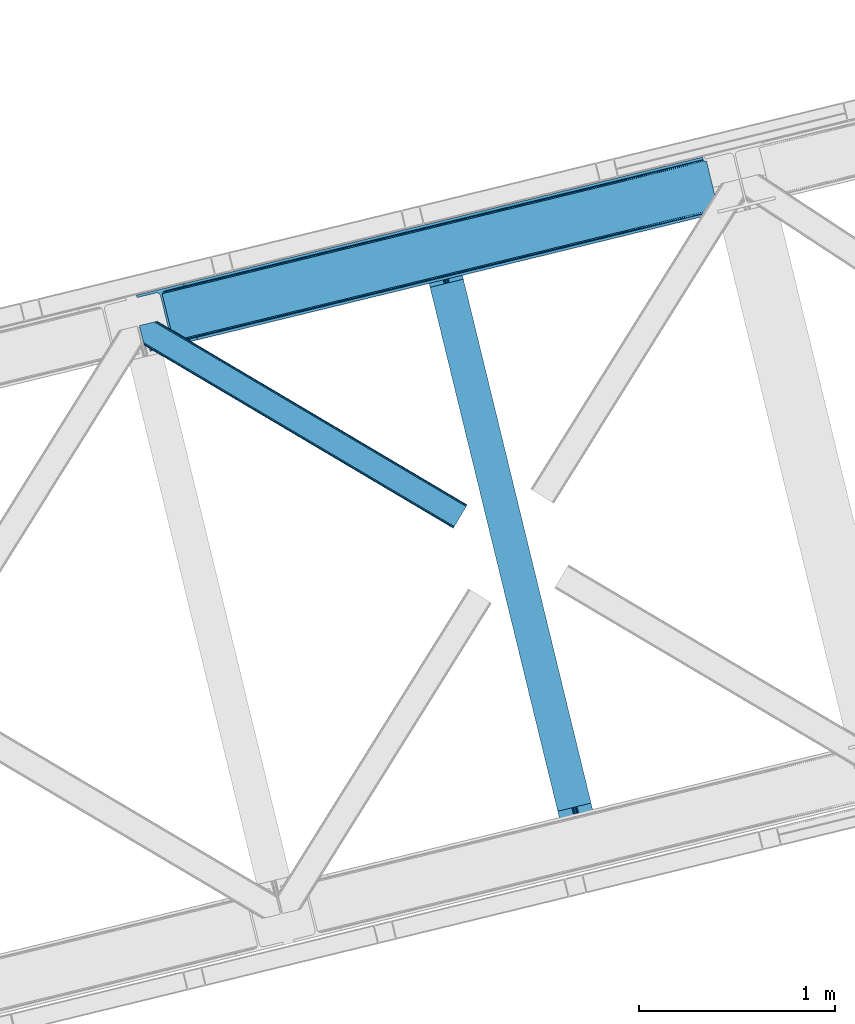
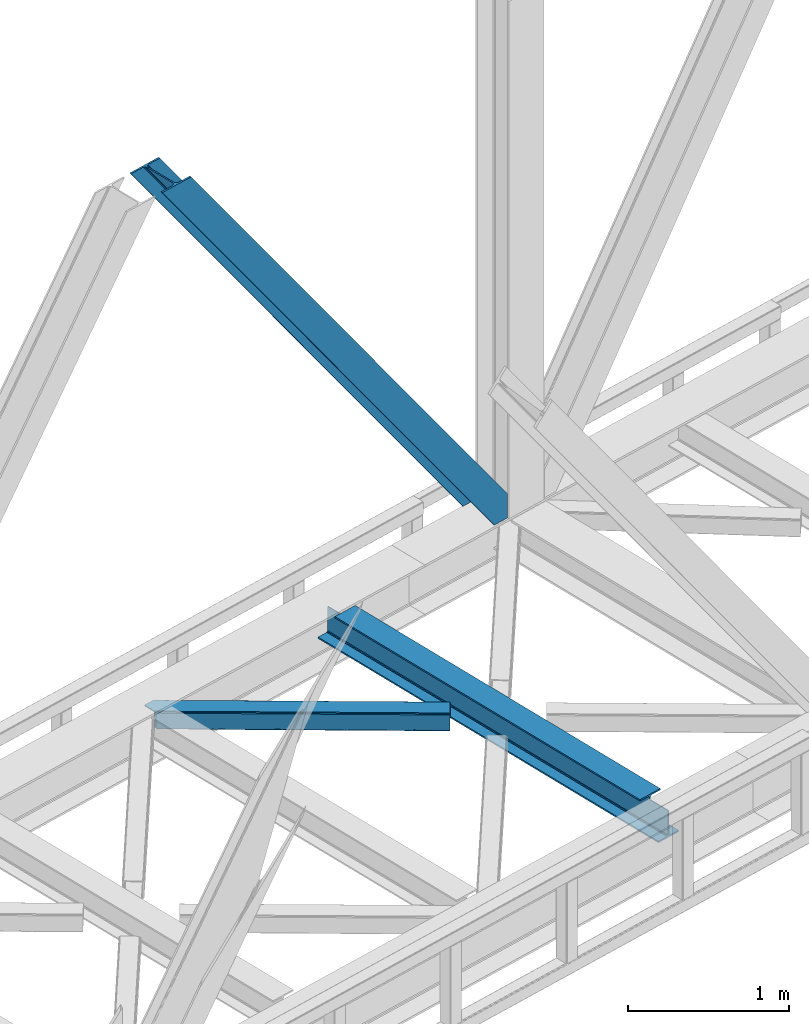
# One storey, part 76 of 92: 2 members, 1 beam.
"""IFC4 building model written with IfcOpenShell, lengths in millimetres."""

from ifc_helpers import new_model, entity, si_unit, converted_unit, derived_unit, direction, frame, origin, place, context, subcontext, project, spatial, triangles, polygons, material, type_object, element, save


model = new_model("IFC4")

# Units and contexts
model_context = context("Model", 3, precision=0.01, world=origin(), true_north=direction((6.12303176911189e-17, 1.0)))
plan_context = context("Plan", 3, precision=0.01, world=origin(), true_north=direction((6.12303176911189e-17, 1.0)))
body_context = subcontext(model_context, "Body", "Model", "MODEL_VIEW")
ifc_project = project(units=[si_unit("LENGTHUNIT", "METRE", prefix="MILLI"), si_unit("AREAUNIT", "SQUARE_METRE"), si_unit("VOLUMEUNIT", "CUBIC_METRE"), converted_unit("PLANEANGLEUNIT", "DEGREE", entity("IfcRatioMeasure", 0.0174532925199433), si_unit("PLANEANGLEUNIT", "RADIAN"), dimensions=[0, 0, 0, 0, 0, 0, 0]), si_unit("MASSUNIT", "GRAM", prefix="KILO"), derived_unit("MASSDENSITYUNIT", [(si_unit("MASSUNIT", "GRAM", prefix="KILO"), 1), (si_unit("LENGTHUNIT", "METRE"), -3)]), derived_unit("MOMENTOFINERTIAUNIT", [(si_unit("LENGTHUNIT", "METRE"), 4)]), si_unit("TIMEUNIT", "SECOND"), si_unit("FREQUENCYUNIT", "HERTZ"), si_unit("THERMODYNAMICTEMPERATUREUNIT", "DEGREE_CELSIUS"), derived_unit("THERMALTRANSMITTANCEUNIT", [(si_unit("MASSUNIT", "GRAM", prefix="KILO"), 1), (si_unit("THERMODYNAMICTEMPERATUREUNIT", "KELVIN"), -1), (si_unit("TIMEUNIT", "SECOND"), -3)]), derived_unit("VOLUMETRICFLOWRATEUNIT", [(si_unit("LENGTHUNIT", "METRE"), 3), (si_unit("TIMEUNIT", "SECOND"), -1)]), derived_unit("MASSFLOWRATEUNIT", [(si_unit("MASSUNIT", "GRAM", prefix="KILO"), 1), (si_unit("TIMEUNIT", "SECOND"), -1)]), derived_unit("ROTATIONALFREQUENCYUNIT", [(si_unit("TIMEUNIT", "SECOND"), -1)]), si_unit("ELECTRICCURRENTUNIT", "AMPERE"), si_unit("ELECTRICVOLTAGEUNIT", "VOLT"), si_unit("POWERUNIT", "WATT"), si_unit("FORCEUNIT", "NEWTON", prefix="KILO"), si_unit("ILLUMINANCEUNIT", "LUX"), si_unit("LUMINOUSFLUXUNIT", "LUMEN"), si_unit("LUMINOUSINTENSITYUNIT", "CANDELA"), derived_unit("USERDEFINED", [(si_unit("MASSUNIT", "GRAM", prefix="KILO"), -1), (si_unit("LENGTHUNIT", "METRE"), -2), (si_unit("TIMEUNIT", "SECOND"), 3), (si_unit("LUMINOUSFLUXUNIT", "LUMEN"), 1)]), derived_unit("LINEARVELOCITYUNIT", [(si_unit("LENGTHUNIT", "METRE"), 1), (si_unit("TIMEUNIT", "SECOND"), -1)]), si_unit("PRESSUREUNIT", "PASCAL"), derived_unit("USERDEFINED", [(si_unit("LENGTHUNIT", "METRE"), -2), (si_unit("MASSUNIT", "GRAM", prefix="KILO"), 1), (si_unit("TIMEUNIT", "SECOND"), -2)]), derived_unit("LINEARFORCEUNIT", [(si_unit("MASSUNIT", "GRAM", prefix="KILO"), 1), (si_unit("LENGTHUNIT", "METRE"), 1), (si_unit("TIMEUNIT", "SECOND"), -2), (si_unit("LENGTHUNIT", "METRE"), -1)]), derived_unit("PLANARFORCEUNIT", [(si_unit("MASSUNIT", "GRAM", prefix="KILO"), 1), (si_unit("LENGTHUNIT", "METRE"), 1), (si_unit("TIMEUNIT", "SECOND"), -2), (si_unit("LENGTHUNIT", "METRE"), -2)])], contexts=[model_context, plan_context])

# Site, building, storey
site_placement = place(None, origin())
site = spatial("IfcSite", under=ifc_project, at=site_placement, CompositionType="ELEMENT")
building_placement = place(site_placement, origin())
building = spatial("IfcBuilding", under=site, at=building_placement, CompositionType="ELEMENT")
storey_placement = place(building_placement, frame((0.0, 0.0, 15900.0)))
storey = spatial("IfcBuildingStorey", under=building, at=storey_placement, Name="05", CompositionType="ELEMENT", Elevation=15900.0)

# Beam
ifc_material = material(Name="Metal painted (White)")
beam_type = type_object("IfcBeamType", PredefinedType="BEAM")
beam_placement = place(storey_placement, frame((-13358.73, 14538.6, 3441.0)))
element("IfcBeam", 1, at=beam_placement, inside=storey, type_object=beam_type, material=ifc_material, ObjectType="Steel Beam", PredefinedType="BEAM", context=body_context, shape_type="Tessellation", body=[
    polygons([(896.722476515612, 41.4445662733146, 11.000000000004), (896.722476515612, 41.4445662733146, 2.16573425859679e-12), (170.021610174759, 3022.65205668042, 2.16573425859679e-12), (170.021610174759, 3022.65205668042, 11.000000000004), (830.656936561986, 25.3403919499678, 11.000000000004), (103.956070221133, 3006.54788235708, 11.000000000004), (824.708186540696, 23.8903211957396, 12.2179274798217), (98.007320199847, 3005.09781160285, 12.2179274798217), (819.665079784591, 22.6610105689216, 15.6862915010192), (92.9642134437384, 3003.86850097603, 15.6862915010192), (816.295383581416, 21.839611468714, 20.8770650821657), (89.5945172405625, 3003.04710187582, 20.8770650821657), (815.11210363173, 21.5511744621227, 27.0000000000047), (88.4112372908766, 3002.75866486924, 27.0000000000047), (81.6103728838844, 3001.1008822183, 27.0000000000047), (81.6103728838844, 3001.1008822183, 203.000000000006), (88.4112372908744, 3002.75866486923, 203.000000000006), (2.16573425859679e-12, 2981.20749040711, 2.16573425859679e-12), (2.16573425859679e-12, 2981.20749040711, 10.9999999999997), (66.0655399536237, 2997.31166473046, 11.000000000004), (72.0142899749227, 2998.76173548469, 12.2179274798217), (77.0573967310248, 2999.99104611151, 15.6862915010192), (80.4270929341986, 3000.81244521171, 20.8770650821613), (815.112103631725, 21.5511744621227, 203.000000000006), (808.311239224738, 19.8933918111897, 203.000000000006), (808.311239224733, 19.8933918111897, 27.0000000000047), (807.127959275049, 19.6049548046006, 20.8770650821613), (803.758263071878, 18.783555704393, 15.6862915010192), (798.715156315771, 17.554245077575, 12.2179274798217), (792.766406294475, 16.1041743233468, 11.000000000004), (726.700866340851, 2.16573425859679e-12, 10.9999999999997), (726.700866340853, 2.16573425859679e-12, 2.16573425859679e-12), (775.94520191196, 182.229070489532, 203.069792164282), (124.290390378917, 2855.56852806081, 203.000000000006), (124.513271168063, 2854.65418562638, 203.617301946336), (124.526185412587, 2854.60120565348, 217.000003693143), (775.799998669233, 182.824605273258, 217.000003676718), (775.800869277131, 182.821033832379, 204.00000679514), (769.234900758907, 180.199471824632, 203.006342981088), (769.012053092183, 181.11382383896, 203.617301946336), (768.999138847659, 181.166803811851, 217.000003693143), (117.725325591011, 2852.94340419208, 217.000003676718), (117.724454983115, 2852.94697563296, 204.00000679514), (117.580155394062, 2853.53894853353, 203.076120467494), (117.489525971921, 2853.91074540987, 203.000000000006), (776.983483393269, 183.112202246699, 223.122939328039), (780.352479801944, 183.936472070578, 228.313710402595), (785.395115205966, 185.167716295884, 231.782072735464), (791.343694076667, 186.618489150563, 232.999999602236), (857.409144942201, 202.723028934504, 232.999999283132), (857.407671605762, 202.729072911373, 243.999994005812), (687.386290701843, 161.283566114482, 243.999994827032), (687.38776403828, 161.277522137611, 233.000000104353), (753.453214903801, 177.382061921545, 232.999999785253), (759.402120032136, 178.83149638977, 231.782072861012), (764.445684539264, 180.058929212901, 228.313710479427), (767.816071448998, 180.87749487033, 223.12293937232), (116.541840866973, 2852.65580721864, 223.122939328039), (113.172844458302, 2851.83153739476, 228.313710402595), (108.13020905428, 2850.60029316945, 231.782072735464), (102.18163018357, 2849.14952031477, 232.999999602236), (36.1161793180448, 2833.04498053083, 232.999999283128), (36.1176526544845, 2833.03893655396, 243.999994005812), (206.139033558403, 2874.48444335085, 243.999994827032), (206.137560221966, 2874.49048732773, 233.000000104357), (140.072109356436, 2858.38594754379, 232.999999785253), (134.12320422811, 2856.93651307556, 231.782072861012), (129.079639720984, 2855.70908025243, 228.313710479427), (125.709252811243, 2854.890514595, 223.12293937232)], [[[1, 2, 3, 4]], [[5, 1, 4, 6]], [[7, 5, 6, 8]], [[9, 7, 8, 10]], [[11, 9, 10, 12]], [[13, 11, 12, 14]], [[15, 16, 17, 14, 12, 10, 8, 6, 4, 3, 18, 19, 20, 21, 22, 23]], [[13, 24, 25, 26, 27, 28, 29, 30, 31, 32, 2, 1, 5, 7, 9, 11]], [[2, 32, 18, 3]], [[32, 31, 19, 18]], [[31, 30, 20, 19]], [[27, 26, 15, 23]], [[28, 27, 23, 22]], [[29, 28, 22, 21]], [[30, 29, 21, 20]], [[33, 24, 13, 14, 17, 34, 35, 36, 37, 38]], [[25, 39, 40, 41, 42, 43, 44, 16, 15, 26]], [[39, 25, 24, 33]], [[45, 34, 17, 16]], [[41, 40, 38, 37, 46, 47, 48, 49, 50, 51, 52, 53, 54, 55, 56, 57]], [[42, 58, 59, 60, 61, 62, 63, 64, 65, 66, 67, 68, 69, 36, 35, 43]], [[46, 37, 36, 69]], [[47, 46, 69, 68]], [[48, 47, 68, 67]], [[49, 48, 67, 66]], [[50, 49, 66, 65]], [[51, 50, 65, 64]], [[52, 51, 64, 63]], [[53, 52, 63, 62]], [[54, 53, 62, 61]], [[55, 54, 61, 60]], [[56, 55, 60, 59]], [[57, 56, 59, 58]], [[41, 57, 58, 42]]], closed=False),
])

# Members
member_type_1 = type_object("IfcMemberType", PredefinedType="BRACE")
member_1_placement = place(storey_placement, frame((-14820.11, 17045.0, 3695.0)))
element("IfcMember", 2, at=member_1_placement, inside=storey, type_object=member_type_1, ObjectType="Steel Vertical Brace", PredefinedType="BRACE", context=body_context, shape_type="Tessellation", body=[
    triangles([(2966.89332275391, 730.998403930666, 0.80925292968459), (2967.55374755859, 730.01590576172, 1.10690917968532), (2966.08058166504, 729.656625366213, 0.0), (2964.18651123047, 737.428244018556, 0.0), (2962.43894348145, 728.768307495116, 8.31577148437282), (2962.43894348145, 728.768307495116, 0.0), (2505.8586730957, 612.605630493166, 658.855133056641), (2511.3606628418, 609.931375122073, 662.301434326171), (2954.04410705566, 717.839904785156, 38.6743835449197), (2954.16968078613, 719.76304321289, 32.1678039550752), (2501.41243286133, 617.533236694337, 656.552947998047), (2958.54266967773, 726.956790161134, 14.8293273925774), (2955.07776489258, 722.24312438965, 26.1867736816384), (2955.64168395996, 723.795355224611, 22.4381652832017), (655.166986083985, 156.054428100586, 3289.34108276367), (649.43826599121, 156.067218017579, 3285.27854003906), (213.883456420897, 48.4865753173835, 3911.00081176758), (205.271191406249, 47.7970825195334, 3911.00081176758), (643.936276245116, 158.7426361084, 3281.83223876953), (197.320513916015, 49.8760253906257, 3911.00081176758), (639.490036010742, 163.669079589843, 3279.53005371094), (191.242977905273, 54.4048187255867, 3911.00081176758), (636.783224487304, 170.100082397461, 3278.7231262207), (187.962945556639, 60.6951324462898, 3911.00081176758), (2954.16154174805, 716.458593750001, 50.6410949707024), (2517.08938293457, 609.917422485352, 666.36397705078), (2051.60849304199, 496.451092529296, 1322.10767211914), (2045.87977294922, 496.465045166016, 1318.04512939453), (1580.39888305664, 382.99871520996, 1973.78882446289), (1586.12760314941, 382.985925292971, 1977.85369262695), (1114.91799316406, 269.533547973635, 2629.53251953125), (1120.64671325684, 269.519595336915, 2633.59738769531), (2040.37778320312, 499.140463256837, 1314.598828125), (1574.89805603027, 385.674133300781, 1970.34484863281), (1109.41716613769, 272.208966064452, 2626.08854370117), (2035.93154296875, 504.066906738281, 1312.29896850586), (1570.45065307617, 390.600576782228, 1968.04266357422), (1104.97092590332, 277.135409545899, 2623.78635864258), (2498.70562133789, 623.963076782227, 655.74602050781), (2033.22473144531, 510.496746826171, 1311.48971557617), (1567.74384155273, 397.031579589846, 1967.23341064453), (1102.26411437988, 283.56524963379, 2622.97710571289), (2909.00615844727, 963.80047302246, 0.0), (2443.52526855469, 850.334143066408, 655.74602050781), (1978.04437866211, 736.868975830079, 1311.48971557617), (1512.56348876953, 623.402645874023, 1967.23341064453), (1047.08376159668, 509.937478637698, 2622.97710571289), (581.602871704101, 396.471148681641, 3278.7231262207), (132.782592773438, 287.06619873047, 3911.00081176758), (307.435885620116, 71.2909973144524, 3911.00081176758), (2954.16154174805, 716.458593750001, 182.433050537107), (2954.35339050293, 715.474932861329, 0.0), (2954.16968078613, 719.76304321289, 0.0), (2954.35339050293, 715.474932861329, 182.495837402341), (2955.64168395996, 723.795355224611, 0.0), (2958.54266967773, 726.956790161134, 0.0), (2957.19507751465, 703.816342163085, 182.495837402341), (310.513604736328, 58.6603729248054, 3911.00081176758), (2957.19507751465, 703.816342163085, 0.0), (2846.09255676269, 676.734274291994, 0.0), (69.8643402099606, 0.0, 3911.00081176758), (2843.01367492676, 689.364898681641, 0.0), (66.7854583740227, 12.6294616699233, 3911.00081176758), (160.337887573241, 35.4338836669922, 3911.00081176758), (2936.56610412598, 712.169320678713, 0.0), (2953.96039123535, 734.936535644531, 0.0), (2953.94295043945, 727.841619873048, 0.0), (177.732174682616, 58.2010986328132, 3911.00081176758), (177.714733886718, 51.1073455810547, 3911.00081176758), (2950.63036193848, 721.023431396487, 0.0), (174.402145385742, 44.2891571044929, 3911.00081176758), (2944.52840881348, 715.520278930664, 0.0), (168.300192260742, 38.7848419189468, 3911.00081176758), (2898.78003845215, 961.307601928711, 0.0), (122.551821899413, 284.573327636721, 3911.00081176758), (2872.85952758789, 973.516159057617, 0.0), (2881.47179260254, 974.205651855471, 0.0), (105.243576049805, 297.47021484375, 3911.00081176758), (96.6313110351548, 296.781884765627, 3911.00081176758), (2889.42130737305, 972.126708984375, 0.0), (113.193090820312, 295.392434692385, 3911.00081176758), (2895.50000610352, 967.597915649414, 0.0), (119.271789550781, 290.863641357424, 3911.00081176758), (3.07888183593604, 273.977462768555, 3911.00081176758), (2779.30709838867, 950.711737060548, 0.0), (2776.22821655273, 963.342361450195, 0.0), (0.0, 286.606924438478, 3911.00081176758), (142.214575195312, 306.482455444337, 3911.00081176758), (150.176879882813, 309.833413696291, 3911.00081176758), (136.111459350584, 300.979302978518, 3911.00081176758), (132.800033569336, 294.161114501952, 3911.00081176758), (240.650427246093, 345.268460083007, 3911.00081176758), (243.729309082031, 332.63783569336, 3911.00081176758), (2887.33073730469, 990.424429321291, 182.495837402341), (2887.33073730469, 990.424429321291, 0.0), (2890.45496520996, 977.805432128906, 182.433050537107), (2890.17358703613, 978.765838623047, 182.495837402341), (1522.42102661133, 644.332763671875, 1977.85369262695), (591.460409545898, 417.401266479494, 3289.34108276367), (1056.94129943848, 530.867596435546, 2633.59738769531), (1987.90191650391, 757.799093627931, 1322.10767211914), (2453.38280639648, 871.26426086426, 666.36397705078), (2890.45496520996, 977.805432128906, 50.6410949707024), (2890.17358703613, 978.765838623047, 0.0), (2890.98749084473, 976.525277709963, 38.6743835449197), (2892.14904785156, 974.998626708984, 33.1630920410134), (2891.98277893066, 974.874215698244, 0.0), (2893.56989135742, 973.138275146484, 26.4425720214822), (2895.14653930664, 971.972067260744, 22.4381652832017), (2903.46928710937, 970.684936523438, 8.31577148437282), (2903.46928710937, 970.684936523438, 0.0), (2899.17652587891, 970.501226806642, 0.0), (2899.17652587891, 970.501226806642, 14.8293273925774), (2895.14653930664, 971.972067260744, 0.0), (2907.11092529297, 971.573254394531, 0.0), (2444.64961853027, 863.708908081055, 658.855133056641), (2442.96948852539, 857.289532470702, 656.552947998047), (2908.44921569824, 970.754699707031, 0.80925292968459), (2908.58409118652, 971.931372070314, 1.10690917968532), (581.047091674804, 403.425375366212, 3279.53005371094), (582.727221679686, 409.845913696288, 3281.83223876953), (586.380487060547, 414.752590942382, 3285.27854003906), (2448.30288391113, 868.615585327148, 662.301434326171), (1977.48859863281, 743.82320251465, 1312.29896850586), (1512.00770874023, 630.358035278321, 1968.04266357422), (1046.52681884766, 516.891705322265, 2623.78635864258), (1979.16872863769, 750.243740844726, 1314.598828125), (1513.68900146484, 636.777410888673, 1970.34484863281), (1048.20811157226, 523.312243652344, 2626.08854370117), (1982.82199401855, 755.15041809082, 1318.04512939453), (1517.3422668457, 641.684088134767, 1973.78882446289), (1051.86137695312, 528.218920898438, 2629.53251953125)], [[1, 2, 3], [3, 4, 1], [2, 5, 6], [6, 3, 2], [7, 8, 9], [9, 10, 7], [11, 12, 5], [5, 1, 11], [11, 7, 13], [13, 14, 11], [14, 12, 11], [15, 16, 17], [18, 17, 16], [16, 19, 18], [20, 18, 19], [19, 21, 20], [22, 20, 21], [21, 23, 22], [24, 22, 23], [5, 2, 1], [10, 13, 7], [25, 9, 8], [8, 26, 25], [26, 8, 27], [28, 27, 8], [27, 28, 29], [29, 30, 27], [30, 29, 31], [31, 32, 30], [32, 31, 16], [16, 15, 32], [8, 7, 33], [33, 28, 8], [28, 33, 34], [34, 29, 28], [29, 34, 31], [35, 31, 34], [31, 35, 16], [19, 16, 35], [7, 11, 33], [36, 33, 11], [33, 36, 34], [37, 34, 36], [34, 37, 35], [38, 35, 37], [35, 38, 21], [21, 19, 35], [1, 4, 11], [39, 11, 4], [11, 39, 36], [40, 36, 39], [36, 40, 37], [41, 37, 40], [37, 41, 38], [42, 38, 41], [38, 42, 21], [23, 21, 42], [4, 43, 44], [45, 39, 44], [41, 40, 45], [41, 45, 46], [44, 39, 4], [45, 40, 39], [42, 41, 46], [46, 47, 42], [47, 48, 23], [49, 24, 48], [47, 23, 42], [48, 24, 23], [50, 51, 30], [30, 32, 50], [32, 15, 50], [17, 50, 15], [27, 30, 51], [51, 25, 26], [26, 27, 51], [52, 9, 25], [52, 53, 10], [10, 9, 52], [25, 51, 54], [54, 52, 25], [14, 53, 55], [53, 14, 13], [10, 53, 13], [56, 12, 55], [14, 55, 12], [6, 5, 56], [12, 56, 5], [57, 54, 58], [54, 51, 50], [50, 58, 54], [57, 59, 52], [52, 54, 57], [58, 60, 57], [58, 61, 60], [60, 59, 57], [62, 60, 63], [61, 63, 60], [63, 64, 62], [65, 62, 64], [66, 67, 68], [69, 68, 67], [67, 70, 69], [71, 69, 70], [70, 72, 71], [73, 71, 72], [72, 65, 73], [64, 73, 65], [74, 66, 75], [68, 75, 66], [76, 77, 78], [78, 79, 76], [77, 80, 81], [81, 78, 77], [80, 82, 83], [83, 81, 80], [82, 74, 75], [75, 83, 82], [79, 84, 85], [85, 76, 79], [86, 85, 87], [84, 87, 85], [75, 68, 49], [71, 73, 18], [64, 61, 17], [63, 61, 64], [73, 64, 17], [68, 69, 22], [69, 71, 20], [81, 88, 78], [87, 79, 89], [79, 78, 89], [87, 84, 79], [81, 83, 90], [83, 75, 91], [49, 68, 24], [17, 18, 73], [22, 69, 20], [18, 20, 71], [22, 24, 68], [58, 17, 61], [58, 50, 17], [89, 78, 88], [90, 83, 91], [49, 91, 75], [90, 88, 81], [89, 92, 87], [92, 89, 93], [92, 86, 87], [86, 92, 94], [95, 86, 94], [96, 97, 93], [97, 94, 92], [92, 93, 97], [98, 96, 93], [93, 99, 100], [99, 93, 89], [100, 98, 93], [96, 98, 101], [101, 102, 96], [103, 96, 102], [97, 104, 94], [95, 94, 104], [104, 105, 106], [96, 103, 97], [104, 97, 103], [103, 105, 104], [107, 108, 109], [107, 106, 108], [110, 111, 112], [112, 113, 110], [113, 112, 114], [114, 109, 113], [109, 114, 107], [106, 107, 104], [53, 70, 55], [76, 86, 95], [85, 86, 76], [77, 76, 95], [104, 80, 77], [77, 95, 104], [104, 107, 80], [60, 65, 59], [52, 72, 70], [65, 72, 59], [60, 62, 65], [70, 53, 52], [52, 59, 72], [43, 66, 74], [82, 112, 74], [80, 114, 82], [80, 107, 114], [82, 114, 112], [111, 43, 74], [112, 111, 74], [43, 111, 115], [4, 66, 43], [56, 66, 6], [55, 70, 67], [67, 66, 56], [56, 55, 67], [4, 6, 66], [3, 6, 4], [116, 113, 109], [117, 118, 113], [113, 116, 117], [109, 108, 116], [118, 119, 110], [110, 113, 118], [48, 120, 91], [91, 49, 48], [120, 121, 90], [90, 91, 120], [121, 122, 88], [88, 90, 121], [122, 99, 89], [89, 88, 122], [105, 103, 123], [102, 123, 103], [106, 116, 108], [116, 106, 105], [123, 116, 105], [43, 118, 44], [117, 44, 118], [44, 117, 124], [124, 45, 44], [45, 124, 125], [125, 46, 45], [46, 125, 126], [126, 47, 46], [47, 126, 120], [120, 48, 47], [117, 116, 127], [127, 124, 117], [124, 127, 128], [128, 125, 124], [125, 128, 129], [129, 126, 125], [126, 129, 121], [121, 120, 126], [116, 123, 127], [130, 127, 123], [127, 130, 128], [131, 128, 130], [128, 131, 132], [132, 129, 128], [129, 132, 122], [122, 121, 129], [123, 102, 101], [101, 130, 123], [130, 101, 131], [98, 131, 101], [131, 98, 132], [100, 132, 98], [132, 100, 122], [99, 122, 100], [110, 119, 111], [115, 111, 119], [119, 118, 115], [43, 115, 118]]),
])
member_type_2 = type_object("IfcMemberType", PredefinedType="BRACE")
member_2_placement = place(storey_placement, frame((-14805.08, 16142.52, 3510.0)))
element("IfcMember", 3, at=member_2_placement, inside=storey, type_object=member_type_2, ObjectType="Steel Horizontal Brace", PredefinedType="BRACE", context=body_context, shape_type="Tessellation", body=[
    triangles([(1672.2153717041, 120.471716308593, 122.500662231447), (1672.2153717041, 120.471716308593, 17.5000946044929), (91.5002288818359, 1056.29133911133, 122.500662231447), (91.5002288818359, 1056.29133911133, 17.5000946044929), (1663.30079956055, 105.412170410156, 139.999594116212), (1666.71221923828, 111.175772094726, 138.667117309571), (76.4813781738285, 1052.62993469238, 138.667117309571), (67.1679931640629, 1050.35914306641, 139.999594116212), (1669.60390319824, 116.060357666016, 134.874325561526), (84.3750823974606, 1054.55423583984, 134.874325561526), (1671.53750610352, 119.325274658202, 129.197927856447), (89.6480163574215, 1055.83904113769, 129.197927856447), (18.7674591064442, 956.992749023439, 139.999594116212), (1609.80987854004, 15.0595458984371, 139.999594116212), (0.0, 1033.98688659668, 139.999594116212), (1600.89065551758, 0.0, 122.500662231447), (1601.57317199707, 1.14644165038953, 129.197927856447), (24.5612915039055, 933.226757812501, 122.500662231447), (24.1206207275391, 935.034786987306, 129.197927856447), (1603.50096130371, 4.41019592285193, 134.874325561526), (22.8637207031243, 940.186798095701, 134.874325561526), (1606.3938079834, 9.29594421386719, 138.667117309571), (20.9847656250004, 947.897955322265, 138.667117309571), (1600.89065551758, 0.0, 17.5000946044929), (24.5612915039055, 933.226757812501, 17.5000946044929), (1671.53750610352, 119.325274658202, 10.8028289794929), (89.5619750976566, 1055.81811218262, 10.8167816162131), (162.73657836914, 1012.41959838867, 10.5005218505867), (1669.60390319824, 116.060357666016, 5.12526855468968), (165.152709960938, 1006.73157348633, 5.12526855468968), (164.096960449218, 1011.06270446777, 9.50058288574292), (163.767910766601, 1011.39059143067, 9.74126586914281), (163.419094848632, 1011.74173278808, 10.0005523681648), (163.065628051758, 1012.09287414551, 10.2586761474631), (89.4724456787098, 1055.79602050781, 10.5005218505867), (1666.71221923828, 111.175772094726, 1.33247680664135), (167.031665039061, 999.020416259764, 1.33247680664135), (1663.30079956055, 105.412170410156, 0.0), (169.248971557618, 989.925622558594, 0.0), (1609.80987854004, 15.0595458984371, 0.0), (204.009640502929, 847.325024414064, 0.0), (166.887487792968, 995.390405273438, 10.5005218505867), (72.0351379394524, 1051.54627990722, 10.5005218505867), (168.582733154297, 992.660339355467, 9.50058288574292), (168.16531677246, 993.33355407715, 9.74591674804833), (167.737435913086, 994.026535034178, 10.0005523681648), (167.304904174804, 994.718353271483, 10.2540252685576), (1666.03667907715, 110.036306762695, 12.1260040283232), (1667.9691192627, 113.301223754883, 17.8035644531265), (79.9148895263661, 1053.46709289551, 17.8035644531265), (1663.14383239746, 105.151721191405, 8.3320495605476), (169.397799682616, 989.3175201416, 8.81690368652562), (74.1129180908192, 1052.05206298828, 12.4271484375022), (171.566271972655, 980.419226074218, 6.99957275390625), (1659.73357543945, 99.3892822265625, 6.99957275390625), (1668.64698486328, 114.447665405272, 24.4996673583992), (81.7682647705078, 1053.91822814941, 24.4996673583992), (1668.64698486328, 114.447665405272, 115.501089477541), (81.7682647705078, 1053.91822814941, 115.501089477541), (74.6419555664052, 1052.18112487793, 127.87475280762), (66.7482513427731, 1050.25682373047, 131.667544555665), (79.9148895263661, 1053.46709289551, 122.196029663086), (57.4348663330074, 1047.98719482422, 133.000021362306), (0.0, 1033.98688659668, 133.000021362306), (1667.9691192627, 113.301223754883, 122.196029663086), (1666.03667907715, 110.036306762695, 127.87475280762), (1663.14383239746, 105.151721191405, 131.667544555665), (1659.73357543945, 99.3892822265625, 133.000021362306), (16.4501586914066, 966.499145507811, 133.000021362306), (1613.37245178223, 21.0824340820309, 133.000021362306), (1613.37245178223, 21.0824340820309, 6.99957275390625), (201.692340087891, 856.831420898436, 6.99957275390625), (1607.06934814453, 10.4342468261711, 127.87475280762), (1609.96103210449, 15.3199951171864, 131.667544555665), (1604.45787963867, 6.02405090331922, 115.501089477541), (1605.13574523926, 7.16932983398328, 122.196029663086), (1606.3938079834, 9.29594421386719, 1.33247680664135), (1607.06934814453, 10.4342468261711, 12.1260040283232), (1603.50096130371, 4.41019592285193, 5.12526855468968), (1609.96103210449, 15.3199951171864, 8.3320495605476), (1601.57317199707, 1.14644165038953, 10.8028289794929), (1604.45787963867, 6.02405090331922, 24.4996673583992), (1605.13574523926, 7.16932983398328, 17.8035644531265), (18.6674652099609, 957.404351806641, 131.667544555665), (20.5464202880848, 949.694357299804, 127.87475280762), (21.8033203124996, 944.542346191405, 122.196029663086), (22.2439910888661, 942.733154296873, 115.501089477541), (22.2439910888661, 942.733154296873, 24.4996673583992), (21.7823913574211, 944.627224731446, 17.8163543701194), (21.7602996826172, 944.71675415039, 17.5000946044929), (203.86081237793, 847.933126831054, 8.81690368652562), (206.226947021485, 838.23023071289, 1.33247680664135), (204.67587890625, 844.590307617187, 9.50058288574292), (208.105902099609, 830.520236206054, 5.12526855468968), (209.161651611328, 826.186779785157, 9.50058288574292), (204.68285522461, 843.326431274412, 10.2075164794951), (204.323574829101, 843.305502319336, 10.3540191650391), (203.965457153321, 843.283410644532, 10.5005218505867), (27.0134674072269, 945.867846679686, 12.1260040283232), (28.3459442138665, 947.254971313478, 10.5005218505867), (204.681692504882, 843.958950805665, 9.85404968261719), (32.138735961913, 930.362979125975, 10.8179443359404), (209.134909057617, 825.982141113282, 9.88311767578125), (208.116366577149, 826.255380249024, 10.5005218505867), (208.802371215821, 826.071670532225, 10.0842681884787), (32.4968536376946, 930.225778198243, 10.5005218505867)], [[1, 2, 3], [4, 3, 2], [5, 6, 7], [7, 8, 5], [6, 9, 10], [10, 7, 6], [9, 11, 12], [12, 10, 9], [11, 1, 3], [3, 12, 11], [5, 13, 14], [13, 5, 8], [15, 13, 8], [16, 17, 18], [19, 18, 17], [17, 20, 19], [21, 19, 20], [20, 22, 21], [23, 21, 22], [22, 14, 23], [13, 23, 14], [24, 16, 18], [18, 25, 24], [26, 27, 4], [27, 26, 28], [26, 29, 30], [30, 31, 26], [26, 32, 33], [32, 26, 31], [26, 34, 28], [34, 26, 33], [28, 35, 27], [29, 36, 37], [37, 30, 29], [36, 38, 39], [39, 37, 36], [4, 2, 26], [38, 40, 41], [41, 39, 38], [28, 42, 35], [43, 35, 42], [31, 44, 45], [45, 32, 31], [32, 45, 46], [46, 33, 32], [33, 46, 47], [47, 34, 33], [34, 47, 42], [42, 28, 34], [48, 49, 50], [45, 51, 46], [45, 44, 51], [42, 47, 51], [47, 46, 51], [44, 52, 51], [48, 53, 42], [42, 51, 48], [53, 43, 42], [51, 52, 54], [54, 55, 51], [50, 53, 48], [49, 56, 57], [57, 50, 49], [56, 58, 59], [59, 57, 56], [60, 61, 7], [10, 60, 7], [10, 12, 62], [60, 10, 62], [62, 12, 3], [61, 8, 7], [15, 63, 64], [15, 8, 63], [61, 63, 8], [62, 3, 59], [57, 4, 50], [3, 57, 59], [4, 27, 50], [3, 4, 57], [35, 50, 27], [35, 53, 50], [35, 43, 53], [58, 65, 59], [62, 59, 65], [65, 66, 62], [60, 62, 66], [66, 67, 60], [61, 60, 67], [67, 68, 61], [63, 61, 68], [68, 69, 63], [68, 70, 69], [69, 64, 63], [71, 55, 72], [54, 72, 55], [11, 66, 65], [58, 2, 1], [11, 65, 1], [11, 9, 66], [65, 58, 1], [66, 9, 6], [68, 5, 14], [5, 67, 6], [67, 5, 68], [67, 66, 6], [26, 48, 29], [56, 2, 58], [2, 49, 26], [49, 2, 56], [26, 49, 48], [38, 55, 40], [36, 29, 48], [48, 51, 36], [51, 55, 38], [38, 36, 51], [73, 22, 20], [14, 70, 68], [14, 74, 70], [74, 14, 22], [73, 74, 22], [75, 16, 24], [17, 76, 73], [20, 17, 73], [76, 17, 16], [75, 76, 16], [77, 78, 79], [40, 55, 71], [71, 80, 40], [80, 78, 77], [77, 40, 80], [81, 79, 78], [24, 82, 75], [83, 24, 81], [24, 83, 82], [83, 81, 78], [70, 74, 84], [84, 69, 70], [74, 73, 85], [85, 84, 74], [73, 76, 86], [86, 85, 73], [76, 75, 87], [87, 86, 76], [75, 82, 87], [88, 87, 82], [86, 87, 18], [18, 19, 86], [21, 86, 19], [86, 21, 85], [18, 88, 25], [89, 90, 25], [25, 88, 89], [87, 88, 18], [84, 23, 13], [15, 69, 13], [64, 69, 15], [84, 85, 23], [23, 85, 21], [69, 84, 13], [44, 30, 37], [39, 44, 37], [54, 52, 39], [54, 39, 72], [30, 44, 31], [39, 52, 44], [72, 41, 91], [41, 92, 93], [41, 72, 39], [94, 93, 92], [41, 93, 91], [94, 95, 93], [83, 89, 88], [71, 72, 91], [78, 96, 97], [97, 98, 78], [98, 99, 78], [98, 100, 99], [80, 91, 93], [93, 78, 80], [78, 93, 101], [101, 96, 78], [83, 78, 99], [99, 90, 83], [90, 89, 83], [91, 80, 71], [88, 82, 83], [24, 25, 102], [79, 103, 95], [81, 102, 104], [104, 79, 81], [104, 105, 79], [95, 94, 79], [40, 77, 92], [92, 41, 40], [77, 79, 94], [94, 92, 77], [106, 81, 24], [99, 106, 25], [99, 100, 106], [25, 90, 99], [98, 104, 106], [106, 100, 98]]),
])

save(model, "model.ifc")
